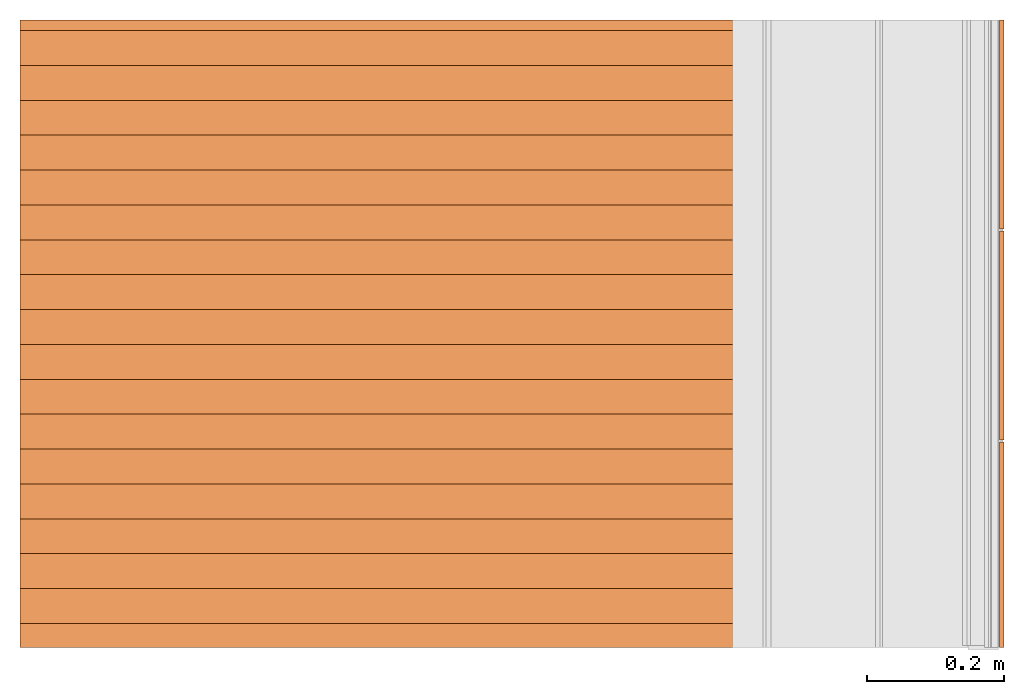
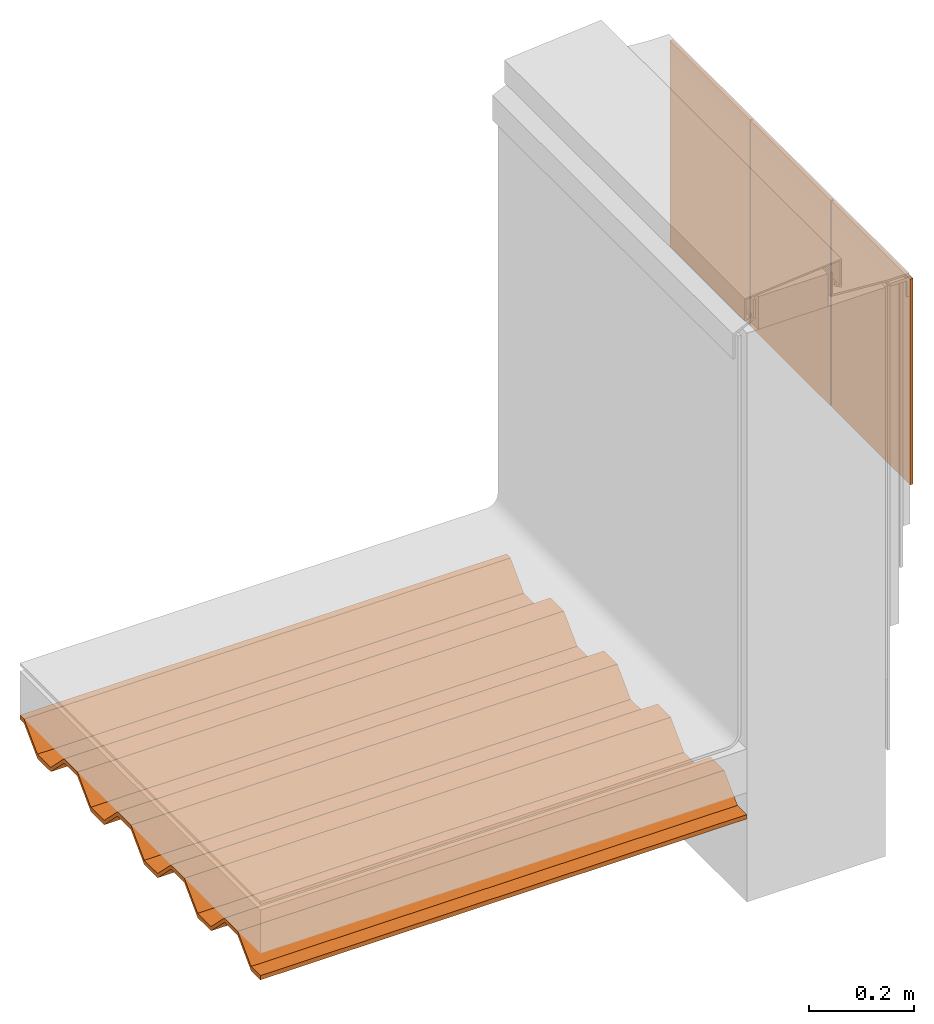
# Not in any storey, part 2 of 2: 2 proxies.
"""IFC4 building model written with IfcOpenShell, lengths in metres."""

from ifc_helpers import new_model, entity, si_unit, converted_unit, direction, origin_with_axes, place, context, project, spatial, faceted_brep, source, transform, mapped, material, element, save


model = new_model("IFC4")

# Units and contexts
model_context = context("Model", 3, precision=1e-05, world=origin_with_axes(), true_north=direction((0.0, 1.0, 0.0)))
ifc_project = project(units=[si_unit("LENGTHUNIT", "METRE"), si_unit("AREAUNIT", "SQUARE_METRE"), si_unit("VOLUMEUNIT", "CUBIC_METRE"), converted_unit("PLANEANGLEUNIT", "DEGREE", entity("IfcPlaneAngleMeasure", 0.017453292519943295), si_unit("PLANEANGLEUNIT", "RADIAN"), dimensions=[0, 0, 0, 0, 0, 0, 0])], contexts=[model_context])

# Site, building
site = spatial("IfcSite", under=ifc_project, CompositionType="ELEMENT")
building = spatial("IfcBuilding", under=site, Name="Default Building", CompositionType="ELEMENT")

# Proxies
ifc_material_1 = material(Name="Porcelain tiles")
shared_shape = source(origin_with_axes(), model_context, "Body", "Brep", [
    faceted_brep([(37.7501320312, 5.1606640625, -2.91038304567337e-14), (37.7501320312, 5.1606640625, 0.00634999999996944), (37.4453320312, 5.1606640625, 0.00634999999996944), (37.4453320312, 5.1606640625, -2.91038304567337e-14), (37.4453320312, 5.1606640625, 0.00634999999996944), (37.4453320312, 5.6388, 0.00634999999996944), (37.4453320312, 5.6388, -2.91038304567337e-14), (37.4453320312, 5.1606640625, -2.91038304567337e-14), (37.7501320312, 5.6388, 0.00634999999996944), (37.7501320312, 5.1606640625, 0.00634999999996944), (37.7501320312, 5.1606640625, -2.91038304567337e-14), (37.7501320312, 5.6388, -2.91038304567337e-14), (37.7501320312, 5.1606640625, -2.91038304567337e-14), (37.4453320312, 5.1606640625, -2.91038304567337e-14), (37.4453320312, 5.6388, -2.91038304567337e-14), (37.7501320312, 5.6388, -2.91038304567337e-14), (37.7501320312, 5.6388, 0.00634999999996944), (37.4453320312, 5.6388, 0.00634999999996944), (37.4453320312, 5.1606640625, 0.00634999999996944), (37.7501320312, 5.1606640625, 0.00634999999996944), (37.7501320312, 5.6388, -2.91038304567337e-14), (37.4453320312, 5.6388, -2.91038304567337e-14), (37.4453320312, 5.6388, 0.00634999999996944), (37.7501320312, 5.6388, 0.00634999999996944)], [[[0, 1, 2, 3]], [[4, 5, 6, 7]], [[8, 9, 10, 11]], [[12, 13, 14, 15]], [[16, 17, 18, 19]], [[20, 21, 22, 23]]]),
    faceted_brep([(38.0574720312, 5.1606640625, -2.91038304567337e-14), (38.0574720312, 5.1606640625, 0.00634999999996944), (37.7526720312, 5.1606640625, 0.00634999999996944), (37.7526720312, 5.1606640625, -2.91038304567337e-14), (37.7526720312, 5.1606640625, 0.00634999999996944), (37.7526720312, 5.6388, 0.00634999999996944), (37.7526720312, 5.6388, -2.91038304567337e-14), (37.7526720312, 5.1606640625, -2.91038304567337e-14), (38.0574720312, 5.6388, 0.00634999999996944), (38.0574720312, 5.1606640625, 0.00634999999996944), (38.0574720312, 5.1606640625, -2.91038304567337e-14), (38.0574720312, 5.6388, -2.91038304567337e-14), (38.0574720312, 5.1606640625, -2.91038304567337e-14), (37.7526720312, 5.1606640625, -2.91038304567337e-14), (37.7526720312, 5.6388, -2.91038304567337e-14), (38.0574720312, 5.6388, -2.91038304567337e-14), (38.0574720312, 5.6388, 0.00634999999996944), (37.7526720312, 5.6388, 0.00634999999996944), (37.7526720312, 5.1606640625, 0.00634999999996944), (38.0574720312, 5.1606640625, 0.00634999999996944), (38.0574720312, 5.6388, -2.91038304567337e-14), (37.7526720312, 5.6388, -2.91038304567337e-14), (37.7526720312, 5.6388, 0.00634999999996944), (38.0574720312, 5.6388, 0.00634999999996944)], [[[0, 1, 2, 3]], [[4, 5, 6, 7]], [[8, 9, 10, 11]], [[12, 13, 14, 15]], [[16, 17, 18, 19]], [[20, 21, 22, 23]]]),
    faceted_brep([(38.3597320312, 5.1606640625, 0.00634999999996944), (38.0600120312, 5.1606640625, 0.00634999999996944), (38.0600120312, 5.1606640625, -2.91038304567337e-14), (38.3597320312, 5.1606640625, -2.91038304567337e-14), (38.3597320312, 5.1606640625, -2.91038304567337e-14), (38.0600120312, 5.1606640625, -2.91038304567337e-14), (38.0600120312, 5.6388, -2.91038304567337e-14), (38.3597320312, 5.6388, -2.91038304567337e-14), (38.3597320312, 5.1606640625, -2.91038304567337e-14), (38.3597320312, 5.6388, -2.91038304567337e-14), (38.3597320312, 5.6388, 0.00634999999996944), (38.3597320312, 5.1606640625, 0.00634999999996944), (38.3597320312, 5.6388, 0.00634999999996944), (38.0600120312, 5.6388, 0.00634999999996944), (38.0600120312, 5.1606640625, 0.00634999999996944), (38.3597320312, 5.1606640625, 0.00634999999996944), (38.0600120312, 5.1606640625, 0.00634999999996944), (38.0600120312, 5.6388, 0.00634999999996944), (38.0600120312, 5.6388, -2.91038304567337e-14), (38.0600120312, 5.1606640625, -2.91038304567337e-14), (38.3597320312, 5.6388, -2.91038304567337e-14), (38.0600120312, 5.6388, -2.91038304567337e-14), (38.0600120312, 5.6388, 0.00634999999996944), (38.3597320312, 5.6388, 0.00634999999996944)], [[[0, 1, 2, 3]], [[4, 5, 6, 7]], [[8, 9, 10, 11]], [[12, 13, 14, 15]], [[16, 17, 18, 19]], [[20, 21, 22, 23]]]),
])
proxy_1_placement = place(None, origin_with_axes())
element("IfcBuildingElementProxy", 1, at=proxy_1_placement, inside=building, material=ifc_material_1, Name="Porcelain tiles 002", PredefinedType="ELEMENT", context=model_context, shape_type="MappedRepresentation", body=[
    mapped(shared_shape, transform((37.970396016836, 13.4681790419, -3.18323145620525e-15), x_axis=(3.33066907387547e-16, -1.0, 1.11022302462516e-16), y_axis=(1.11022302462516e-16, 1.11022302462516e-16, 1.0), z_axis=(-1.0, -3.33066907387547e-16, 1.11022302462516e-16), scale=1.0)),
])
ifc_material_2 = material(Name="Steel deck")
proxy_2_placement = place(None, origin_with_axes())
element("IfcBuildingElementProxy", 2, at=proxy_2_placement, inside=building, material=ifc_material_2, Name="Steel deck 002", PredefinedType="ELEMENT", context=model_context, shape_type="Brep", body=[
    faceted_brep([(36.536961858636, -24.8915529893, 4.5212), (37.605271016766, -24.8915529893, 4.5212), (37.605271016766, -24.8561936536848, 4.5212), (36.536961858636, -24.8561936536848, 4.5212), (36.536961858636, -24.8915529893, 4.5112), (37.605271016766, -24.8915529893, 4.5112), (37.605271016766, -24.8915529893, 4.5212), (36.536961858636, -24.8915529893, 4.5212), (36.536961858636, -24.8561936536848, 4.5112), (37.605271016766, -24.8561936536848, 4.5112), (37.605271016766, -24.8915529893, 4.5112), (36.536961858636, -24.8915529893, 4.5112), (36.536961858636, -24.8053936536848, 4.562), (37.605271016766, -24.8053936536848, 4.562), (37.605271016766, -24.8561936536848, 4.5112), (36.536961858636, -24.8561936536848, 4.5112), (36.536961858636, -24.7545936536848, 4.562), (37.605271016766, -24.7545936536848, 4.562), (37.605271016766, -24.8053936536848, 4.562), (36.536961858636, -24.8053936536848, 4.562), (36.536961858636, -24.7037936536848, 4.5112), (37.605271016766, -24.7037936536848, 4.5112), (37.605271016766, -24.7545936536848, 4.562), (36.536961858636, -24.7545936536848, 4.562), (36.536961858636, -24.6529936536848, 4.5112), (37.605271016766, -24.6529936536848, 4.5112), (37.605271016766, -24.7037936536848, 4.5112), (36.536961858636, -24.7037936536848, 4.5112), (36.536961858636, -24.6021936536848, 4.56200000000001), (37.605271016766, -24.6021936536848, 4.56200000000001), (37.605271016766, -24.6529936536848, 4.5112), (36.536961858636, -24.6529936536848, 4.5112), (36.536961858636, -24.5513936536848, 4.56200000000001), (37.605271016766, -24.5513936536848, 4.56200000000001), (37.605271016766, -24.6021936536848, 4.56200000000001), (36.536961858636, -24.6021936536848, 4.56200000000001), (36.536961858636, -24.5005936536848, 4.5112), (37.605271016766, -24.5005936536848, 4.5112), (37.605271016766, -24.5513936536848, 4.56200000000001), (36.536961858636, -24.5513936536848, 4.56200000000001), (36.536961858636, -24.4497936536848, 4.5112), (37.605271016766, -24.4497936536848, 4.5112), (37.605271016766, -24.5005936536848, 4.5112), (36.536961858636, -24.5005936536848, 4.5112), (36.536961858636, -24.3989936536848, 4.56200000000001), (37.605271016766, -24.3989936536848, 4.56200000000001), (37.605271016766, -24.4497936536848, 4.5112), (36.536961858636, -24.4497936536848, 4.5112), (36.536961858636, -24.3481936536848, 4.56200000000001), (37.605271016766, -24.3481936536848, 4.56200000000001), (37.605271016766, -24.3989936536848, 4.56200000000001), (36.536961858636, -24.3989936536848, 4.56200000000001), (36.536961858636, -24.2973936536848, 4.5112), (37.605271016766, -24.2973936536848, 4.5112), (37.605271016766, -24.3481936536848, 4.56200000000001), (36.536961858636, -24.3481936536848, 4.56200000000001), (36.536961858636, -24.2465936536848, 4.5112), (37.605271016766, -24.2465936536848, 4.5112), (37.605271016766, -24.2973936536848, 4.5112), (36.536961858636, -24.2973936536848, 4.5112), (36.536961858636, -24.1957936536848, 4.56200000000001), (37.605271016766, -24.1957936536848, 4.56200000000001), (37.605271016766, -24.2465936536848, 4.5112), (36.536961858636, -24.2465936536848, 4.5112), (36.536961858636, -24.1449936536848, 4.56200000000001), (37.605271016766, -24.1449936536848, 4.56200000000001), (37.605271016766, -24.1957936536848, 4.56200000000001), (36.536961858636, -24.1957936536848, 4.56200000000001), (36.536961858636, -24.0941936536848, 4.51120000000001), (37.605271016766, -24.0941936536848, 4.51120000000001), (37.605271016766, -24.1449936536848, 4.56200000000001), (36.536961858636, -24.1449936536848, 4.56200000000001), (36.536961858636, -24.0433936536848, 4.51120000000001), (37.605271016766, -24.0433936536848, 4.51120000000001), (37.605271016766, -24.0941936536848, 4.51120000000001), (36.536961858636, -24.0941936536848, 4.51120000000001), (36.536961858636, -23.9925936536848, 4.56200000000001), (37.605271016766, -23.9925936536848, 4.56200000000001), (37.605271016766, -24.0433936536848, 4.51120000000001), (36.536961858636, -24.0433936536848, 4.51120000000001), (36.536961858636, -23.9771529893, 4.56200000000001), (37.605271016766, -23.9771529893, 4.56200000000001), (37.605271016766, -23.9925936536848, 4.56200000000001), (36.536961858636, -23.9925936536848, 4.56200000000001), (36.536961858636, -23.9771529893, 4.57200000000001), (37.605271016766, -23.9771529893, 4.57200000000001), (37.605271016766, -23.9771529893, 4.56200000000001), (36.536961858636, -23.9771529893, 4.56200000000001), (36.536961858636, -23.9925936536848, 4.57200000000001), (37.605271016766, -23.9925936536848, 4.57200000000001), (37.605271016766, -23.9771529893, 4.57200000000001), (36.536961858636, -23.9771529893, 4.57200000000001), (36.536961858636, -24.0433936536848, 4.52120000000001), (37.605271016766, -24.0433936536848, 4.52120000000001), (37.605271016766, -23.9925936536848, 4.57200000000001), (36.536961858636, -23.9925936536848, 4.57200000000001), (36.536961858636, -24.0941936536848, 4.52120000000001), (37.605271016766, -24.0941936536848, 4.52120000000001), (37.605271016766, -24.0433936536848, 4.52120000000001), (36.536961858636, -24.0433936536848, 4.52120000000001), (36.536961858636, -24.1449936536848, 4.57200000000001), (37.605271016766, -24.1449936536848, 4.57200000000001), (37.605271016766, -24.0941936536848, 4.52120000000001), (36.536961858636, -24.0941936536848, 4.52120000000001), (36.536961858636, -24.1957936536848, 4.57200000000001), (37.605271016766, -24.1957936536848, 4.57200000000001), (37.605271016766, -24.1449936536848, 4.57200000000001), (36.536961858636, -24.1449936536848, 4.57200000000001), (36.536961858636, -24.2465936536848, 4.52120000000001), (37.605271016766, -24.2465936536848, 4.52120000000001), (37.605271016766, -24.1957936536848, 4.57200000000001), (36.536961858636, -24.1957936536848, 4.57200000000001), (36.536961858636, -24.2973936536848, 4.52120000000001), (37.605271016766, -24.2973936536848, 4.52120000000001), (37.605271016766, -24.2465936536848, 4.52120000000001), (36.536961858636, -24.2465936536848, 4.52120000000001), (36.536961858636, -24.3481936536848, 4.57200000000001), (37.605271016766, -24.3481936536848, 4.57200000000001), (37.605271016766, -24.2973936536848, 4.52120000000001), (36.536961858636, -24.2973936536848, 4.52120000000001), (36.536961858636, -24.3989936536848, 4.57200000000001), (37.605271016766, -24.3989936536848, 4.57200000000001), (37.605271016766, -24.3481936536848, 4.57200000000001), (36.536961858636, -24.3481936536848, 4.57200000000001), (36.536961858636, -24.4497936536848, 4.52120000000001), (37.605271016766, -24.4497936536848, 4.52120000000001), (37.605271016766, -24.3989936536848, 4.57200000000001), (36.536961858636, -24.3989936536848, 4.57200000000001), (36.536961858636, -24.5005936536848, 4.52120000000001), (37.605271016766, -24.5005936536848, 4.52120000000001), (37.605271016766, -24.4497936536848, 4.52120000000001), (36.536961858636, -24.4497936536848, 4.52120000000001), (36.536961858636, -24.5513936536848, 4.57200000000001), (37.605271016766, -24.5513936536848, 4.57200000000001), (37.605271016766, -24.5005936536848, 4.52120000000001), (36.536961858636, -24.5005936536848, 4.52120000000001), (36.536961858636, -24.6021936536848, 4.57200000000001), (37.605271016766, -24.6021936536848, 4.57200000000001), (37.605271016766, -24.5513936536848, 4.57200000000001), (36.536961858636, -24.5513936536848, 4.57200000000001), (36.536961858636, -24.6529936536848, 4.5212), (37.605271016766, -24.6529936536848, 4.5212), (37.605271016766, -24.6021936536848, 4.57200000000001), (36.536961858636, -24.6021936536848, 4.57200000000001), (36.536961858636, -24.7037936536848, 4.52120000000001), (37.605271016766, -24.7037936536848, 4.52120000000001), (37.605271016766, -24.6529936536848, 4.5212), (36.536961858636, -24.6529936536848, 4.5212), (36.536961858636, -24.7545936536848, 4.572), (37.605271016766, -24.7545936536848, 4.572), (37.605271016766, -24.7037936536848, 4.52120000000001), (36.536961858636, -24.7037936536848, 4.52120000000001), (36.536961858636, -24.8053936536848, 4.572), (37.605271016766, -24.8053936536848, 4.572), (37.605271016766, -24.7545936536848, 4.572), (36.536961858636, -24.7545936536848, 4.572), (36.536961858636, -24.8561936536848, 4.5212), (37.605271016766, -24.8561936536848, 4.5212), (37.605271016766, -24.8053936536848, 4.572), (36.536961858636, -24.8053936536848, 4.572), (36.536961858636, -24.8915529893, 4.5112), (36.536961858636, -24.8561936536848, 4.5112), (36.536961858636, -24.8053936536848, 4.562), (36.536961858636, -24.7545936536848, 4.562), (36.536961858636, -24.7037936536848, 4.5112), (36.536961858636, -24.6529936536848, 4.5112), (36.536961858636, -24.6021936536848, 4.56200000000001), (36.536961858636, -24.5513936536848, 4.56200000000001), (36.536961858636, -24.5005936536848, 4.5112), (36.536961858636, -24.4497936536848, 4.5112), (36.536961858636, -24.3989936536848, 4.56200000000001), (36.536961858636, -24.3481936536848, 4.56200000000001), (36.536961858636, -24.2973936536848, 4.5112), (36.536961858636, -24.2465936536848, 4.5112), (36.536961858636, -24.1957936536848, 4.56200000000001), (36.536961858636, -24.1449936536848, 4.56200000000001), (36.536961858636, -24.0941936536848, 4.51120000000001), (36.536961858636, -24.0433936536848, 4.51120000000001), (36.536961858636, -23.9925936536848, 4.56200000000001), (36.536961858636, -23.9771529893, 4.56200000000001), (36.536961858636, -23.9771529893, 4.57200000000001), (36.536961858636, -23.9925936536848, 4.57200000000001), (36.536961858636, -24.0433936536848, 4.52120000000001), (36.536961858636, -24.0941936536848, 4.52120000000001), (36.536961858636, -24.1449936536848, 4.57200000000001), (36.536961858636, -24.1957936536848, 4.57200000000001), (36.536961858636, -24.2465936536848, 4.52120000000001), (36.536961858636, -24.2973936536848, 4.52120000000001), (36.536961858636, -24.3481936536848, 4.57200000000001), (36.536961858636, -24.3989936536848, 4.57200000000001), (36.536961858636, -24.4497936536848, 4.52120000000001), (36.536961858636, -24.5005936536848, 4.52120000000001), (36.536961858636, -24.5513936536848, 4.57200000000001), (36.536961858636, -24.6021936536848, 4.57200000000001), (36.536961858636, -24.6529936536848, 4.5212), (36.536961858636, -24.7037936536848, 4.52120000000001), (36.536961858636, -24.7545936536848, 4.572), (36.536961858636, -24.8053936536848, 4.572), (36.536961858636, -24.8561936536848, 4.5212), (36.536961858636, -24.8915529893, 4.5212), (37.605271016766, -24.8915529893, 4.5212), (37.605271016766, -24.8561936536848, 4.5212), (37.605271016766, -24.8053936536848, 4.572), (37.605271016766, -24.7545936536848, 4.572), (37.605271016766, -24.7037936536848, 4.52120000000001), (37.605271016766, -24.6529936536848, 4.5212), (37.605271016766, -24.6021936536848, 4.57200000000001), (37.605271016766, -24.5513936536848, 4.57200000000001), (37.605271016766, -24.5005936536848, 4.52120000000001), (37.605271016766, -24.4497936536848, 4.52120000000001), (37.605271016766, -24.3989936536848, 4.57200000000001), (37.605271016766, -24.3481936536848, 4.57200000000001), (37.605271016766, -24.2973936536848, 4.52120000000001), (37.605271016766, -24.2465936536848, 4.52120000000001), (37.605271016766, -24.1957936536848, 4.57200000000001), (37.605271016766, -24.1449936536848, 4.57200000000001), (37.605271016766, -24.0941936536848, 4.52120000000001), (37.605271016766, -24.0433936536848, 4.52120000000001), (37.605271016766, -23.9925936536848, 4.57200000000001), (37.605271016766, -23.9771529893, 4.57200000000001), (37.605271016766, -23.9771529893, 4.56200000000001), (37.605271016766, -23.9925936536848, 4.56200000000001), (37.605271016766, -24.0433936536848, 4.51120000000001), (37.605271016766, -24.0941936536848, 4.51120000000001), (37.605271016766, -24.1449936536848, 4.56200000000001), (37.605271016766, -24.1957936536848, 4.56200000000001), (37.605271016766, -24.2465936536848, 4.5112), (37.605271016766, -24.2973936536848, 4.5112), (37.605271016766, -24.3481936536848, 4.56200000000001), (37.605271016766, -24.3989936536848, 4.56200000000001), (37.605271016766, -24.4497936536848, 4.5112), (37.605271016766, -24.5005936536848, 4.5112), (37.605271016766, -24.5513936536848, 4.56200000000001), (37.605271016766, -24.6021936536848, 4.56200000000001), (37.605271016766, -24.6529936536848, 4.5112), (37.605271016766, -24.7037936536848, 4.5112), (37.605271016766, -24.7545936536848, 4.562), (37.605271016766, -24.8053936536848, 4.562), (37.605271016766, -24.8561936536848, 4.5112), (37.605271016766, -24.8915529893, 4.5112)], [[[0, 1, 2, 3]], [[4, 5, 6, 7]], [[8, 9, 10, 11]], [[12, 13, 14, 15]], [[16, 17, 18, 19]], [[20, 21, 22, 23]], [[24, 25, 26, 27]], [[28, 29, 30, 31]], [[32, 33, 34, 35]], [[36, 37, 38, 39]], [[40, 41, 42, 43]], [[44, 45, 46, 47]], [[48, 49, 50, 51]], [[52, 53, 54, 55]], [[56, 57, 58, 59]], [[60, 61, 62, 63]], [[64, 65, 66, 67]], [[68, 69, 70, 71]], [[72, 73, 74, 75]], [[76, 77, 78, 79]], [[80, 81, 82, 83]], [[84, 85, 86, 87]], [[88, 89, 90, 91]], [[92, 93, 94, 95]], [[96, 97, 98, 99]], [[100, 101, 102, 103]], [[104, 105, 106, 107]], [[108, 109, 110, 111]], [[112, 113, 114, 115]], [[116, 117, 118, 119]], [[120, 121, 122, 123]], [[124, 125, 126, 127]], [[128, 129, 130, 131]], [[132, 133, 134, 135]], [[136, 137, 138, 139]], [[140, 141, 142, 143]], [[144, 145, 146, 147]], [[148, 149, 150, 151]], [[152, 153, 154, 155]], [[156, 157, 158, 159]], [[160, 161, 162, 163, 164, 165, 166, 167, 168, 169, 170, 171, 172, 173, 174, 175, 176, 177, 178, 179, 180, 181, 182, 183, 184, 185, 186, 187, 188, 189, 190, 191, 192, 193, 194, 195, 196, 197, 198, 199]], [[200, 201, 202, 203, 204, 205, 206, 207, 208, 209, 210, 211, 212, 213, 214, 215, 216, 217, 218, 219, 220, 221, 222, 223, 224, 225, 226, 227, 228, 229, 230, 231, 232, 233, 234, 235, 236, 237, 238, 239]]]),
])

save(model, "model.ifc")
